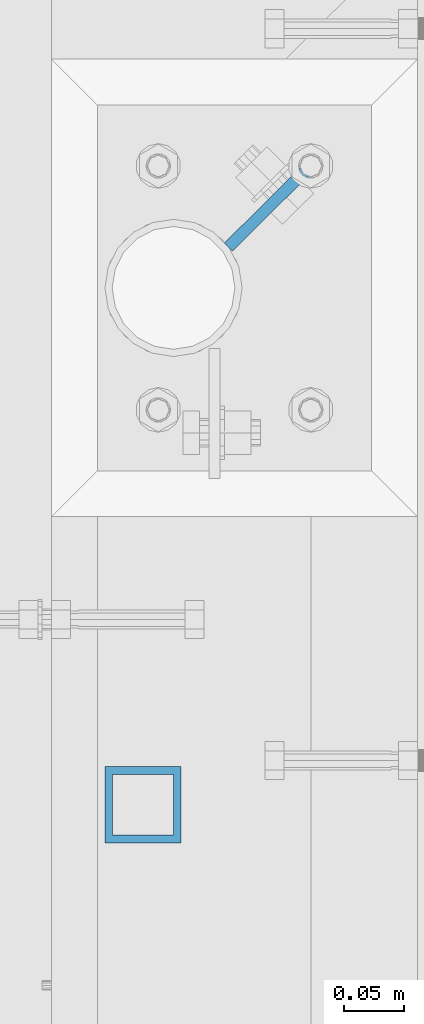
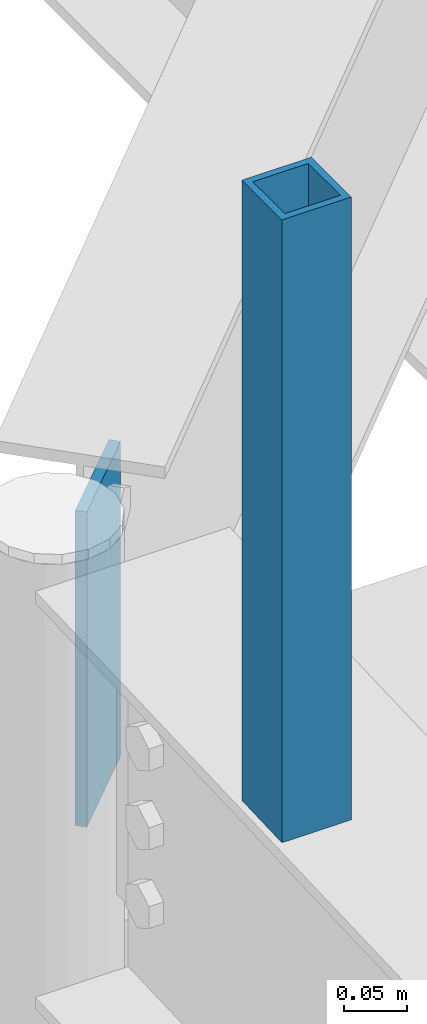
# One storey, part 208 of 975: 2 columns.
"""IFC2X3 building model written with IfcOpenShell, lengths in millimetres."""

import ifcopenshell
import ifcopenshell.guid

model = None  # the IFC model being written
_history = None  # IfcOwnerHistory: only IFC2X3 demands one
_inside = {}  # id of a spatial element -> (the spatial element, [elements in it])
_under = {}  # id of a project, library or spatial element -> (it, [spatial elements below it])
_declared = {}  # id of a project -> (the project, [libraries it declares])
_typed = {}  # id of a type object -> (the type object, [elements of that type])
_made_of = {}  # id of a material, layer set ... -> (it, [elements and type objects made of it])


def new_model(schema):
    """Start an empty IFC model of exactly this schema.

    Asked for "IFC4X3", IfcOpenShell would pick the latest addendum, in which some entities
    have other attributes; the version numbers below select the first issue.
    IFC2X3 requires an IfcOwnerHistory on every rooted entity: one is made here for all.
    """
    global model, _history
    if schema == "IFC4X3":
        model = ifcopenshell.file(schema_version=(4, 3, 0, 0))
    else:
        model = ifcopenshell.file(schema=schema)
    _inside.clear()
    _under.clear()
    _declared.clear()
    _typed.clear()
    _made_of.clear()
    _history = None
    if model.schema == "IFC2X3":
        org = make("IfcOrganization", Name="unknown")
        user = make(
            "IfcPersonAndOrganization",
            ThePerson=make("IfcPerson", FamilyName="unknown"),
            TheOrganization=org,
        )
        app = make(
            "IfcApplication",
            ApplicationDeveloper=org,
            Version="unknown",
            ApplicationFullName="unknown",
            ApplicationIdentifier="unknown",
        )
        _history = make(
            "IfcOwnerHistory",
            OwningUser=user,
            OwningApplication=app,
            ChangeAction="ADDED",
            CreationDate=0,
        )
    return model


def make(cls, **values):
    """One entity of the class cls with the attributes given. An attribute that is None is left unset."""
    return model.create_entity(
        cls, **{name: value for name, value in values.items() if value is not None}
    )


def rooted(cls, **values):
    """An entity with a GlobalId (a new one), such as an element, a storey or a relation."""
    return make(cls, GlobalId=ifcopenshell.guid.new(), OwnerHistory=_history, **values)


def si_unit(unit_type, name, prefix=None):
    """IfcSIUnit, for example si_unit("LENGTHUNIT", "METRE", prefix="MILLI")."""
    return make("IfcSIUnit", UnitType=unit_type, Prefix=prefix, Name=name)


def assignment(units):
    """IfcUnitAssignment: the units of a project."""
    return None if units is None else make("IfcUnitAssignment", Units=units)


def point(xyz):
    """IfcCartesianPoint."""
    return None if xyz is None else make("IfcCartesianPoint", Coordinates=xyz)


def direction(xyz):
    """IfcDirection."""
    return None if xyz is None else make("IfcDirection", DirectionRatios=xyz)


def frame(location, z_axis=None, x_axis=None):
    """IfcAxis2Placement3D, a coordinate frame: its origin and axes. An axis left out is left unset."""
    return make(
        "IfcAxis2Placement3D",
        Location=point(location),
        Axis=direction(z_axis),
        RefDirection=direction(x_axis),
    )


def origin_with_axes():
    """The frame at (0, 0, 0) with the z axis (0, 0, 1) and the x axis (1, 0, 0) written out."""
    return frame((0.0, 0.0, 0.0), z_axis=(0.0, 0.0, 1.0), x_axis=(1.0, 0.0, 0.0))


def place(relative_to, where):
    """IfcLocalPlacement: puts the frame where relative to a parent placement (None: the world)."""
    return make(
        "IfcLocalPlacement", PlacementRelTo=relative_to, RelativePlacement=where
    )


def context(
    kind, dimensions, precision=None, world=None, true_north=None, identifier=None
):
    """IfcGeometricRepresentationContext, for example the 3D "Model" context."""
    return make(
        "IfcGeometricRepresentationContext",
        ContextIdentifier=identifier,
        ContextType=kind,
        CoordinateSpaceDimension=dimensions,
        Precision=precision,
        WorldCoordinateSystem=world,
        TrueNorth=true_north,
    )


def subcontext(parent, identifier, kind, view, scale=None):
    """IfcGeometricRepresentationSubContext, for example "Body" below "Model"."""
    return make(
        "IfcGeometricRepresentationSubContext",
        ContextIdentifier=identifier,
        ContextType=kind,
        ParentContext=parent,
        TargetScale=scale,
        TargetView=view,
    )


def project(units=None, contexts=None):
    """IfcProject with its units and contexts."""
    return rooted(
        "IfcProject",
        Name="project",
        RepresentationContexts=contexts,
        UnitsInContext=assignment(units),
    )


def spatial(cls, under=None, at=None, **own):
    """A site, building, storey or space (cls), placed at a placement, below another one or the project."""
    s = rooted(cls, ObjectPlacement=at, **own)
    if under is not None:
        _under.setdefault(under.id(), (under, []))[1].append(s)
    return s


def faces_of(points, faces, orient=None, outer=None):
    """IfcFace entities. A face is a list of loops; a loop is a list of indices into points, from 0.

    orient and outer hold one flag for each loop. By default every Orientation is true, the
    first loop of a face is its IfcFaceOuterBound and the others are IfcFaceBound.
    """
    made = []
    for i, loops in enumerate(faces):
        bounds = []
        for j, loop in enumerate(loops):
            is_outer = j == 0 if outer is None else outer[i][j]
            bounds.append(
                make(
                    "IfcFaceOuterBound" if is_outer else "IfcFaceBound",
                    Bound=make("IfcPolyLoop", Polygon=[points[k] for k in loop]),
                    Orientation=True if orient is None else orient[i][j],
                )
            )
        made.append(make("IfcFace", Bounds=bounds))
    return made


def faceted_brep(points, faces, orient=None, outer=None, voids=None):
    """IfcFacetedBrep: a solid bounded by flat faces; with voids (closed shells), ...WithVoids."""
    shared = [point(p) for p in points]
    hull = make("IfcClosedShell", CfsFaces=faces_of(shared, faces, orient, outer))
    if voids is None:
        return make("IfcFacetedBrep", Outer=hull)
    return make(
        "IfcFacetedBrepWithVoids",
        Outer=hull,
        Voids=[
            make(cls, CfsFaces=faces_of(shared, fs, o, b)) for cls, fs, o, b in voids
        ],
    )


def shape(context_of_items, identifier, shape_type, items):
    """IfcShapeRepresentation: the items that make up one representation, for example the "Body"."""
    return make(
        "IfcShapeRepresentation",
        ContextOfItems=context_of_items,
        RepresentationIdentifier=identifier,
        RepresentationType=shape_type,
        Items=items,
    )


def material(Name=None, Category=None):
    """IfcMaterial."""
    return make("IfcMaterial", Name=Name, Category=Category)


def made_of(thing, what):
    """Note that an element or type object is made of a material, layer set ...; save() writes the relation."""
    if what is not None:
        _made_of.setdefault(what.id(), (what, []))[1].append(thing)
    return thing


def type_object(cls, material=None, **own):
    """A type object (cls), such as IfcWallType, which elements share."""
    return made_of(rooted(cls, **own), material)


def element(
    cls,
    number,
    at=None,
    inside=None,
    cuts=None,
    type_object=None,
    material=None,
    context=None,
    identifier="Body",
    shape_type=None,
    held_by="IfcProductDefinitionShape",
    body=None,
    shapes=None,
    **own,
):
    """One element of the class cls, such as IfcWall. Its Tag is "e" and its number.

    at: its placement. inside: the storey or other place that contains it. cuts: it is an
    opening in that element (IfcRelVoidsElement). A single representation is given by context,
    identifier, shape_type and body (its items); several are given by shapes. held_by: the class
    of the entity that holds the representations. save() writes the other relations.
    """
    e = rooted(cls, Tag="e%d" % number, ObjectPlacement=at, **own)
    if body is not None:
        shapes = [shape(context, identifier, shape_type, body)]
    if shapes is not None:
        e.Representation = make(held_by, Representations=shapes)
    if inside is not None:
        _inside.setdefault(inside.id(), (inside, []))[1].append(e)
    if cuts is not None:
        rooted(
            "IfcRelVoidsElement", RelatingBuildingElement=cuts, RelatedOpeningElement=e
        )
    if type_object is not None:
        _typed.setdefault(type_object.id(), (type_object, []))[1].append(e)
    return made_of(e, material)


def aggregate(whole, parts):
    """IfcRelAggregates: a whole, such as a stair, and the parts it consists of."""
    return rooted("IfcRelAggregates", RelatingObject=whole, RelatedObjects=parts)


def save(model, path):
    """Write the relations noted so far, then the file.

    IfcRelAggregates (storeys below a building ...), IfcRelContainedInSpatialStructure (elements
    in a storey), IfcRelDefinesByType, IfcRelAssociatesMaterial and IfcRelDeclares: one each for
    every whole, place, type object, material and project.
    """
    for whole, parts in _under.values():
        aggregate(whole, parts)
    for where, things in _inside.values():
        rooted(
            "IfcRelContainedInSpatialStructure",
            RelatedElements=things,
            RelatingStructure=where,
        )
    for kind, things in _typed.values():
        rooted("IfcRelDefinesByType", RelatedObjects=things, RelatingType=kind)
    for what, things in _made_of.values():
        rooted("IfcRelAssociatesMaterial", RelatedObjects=things, RelatingMaterial=what)
    for by, libraries in _declared.values():
        rooted("IfcRelDeclares", RelatingContext=by, RelatedDefinitions=libraries)
    model.write(path)


model = new_model("IFC2X3")

# Units and contexts
model_context = context("Model", 3, precision=1e-05, world=origin_with_axes())
body_context = subcontext(model_context, "Body", "Model", "MODEL_VIEW")
ifc_project = project(units=[si_unit("LENGTHUNIT", "METRE", prefix="MILLI"), si_unit("AREAUNIT", "SQUARE_METRE"), si_unit("VOLUMEUNIT", "CUBIC_METRE"), si_unit("MASSUNIT", "GRAM", prefix="KILO"), si_unit("TIMEUNIT", "SECOND"), si_unit("PLANEANGLEUNIT", "RADIAN"), si_unit("SOLIDANGLEUNIT", "STERADIAN"), si_unit("THERMODYNAMICTEMPERATUREUNIT", "DEGREE_CELSIUS"), si_unit("LUMINOUSINTENSITYUNIT", "LUMEN")], contexts=[model_context])

# Site, building, storey
site_placement = place(None, origin_with_axes())
site = spatial("IfcSite", under=ifc_project, at=site_placement, CompositionType="ELEMENT")
building_placement = place(site_placement, origin_with_axes())
building = spatial("IfcBuilding", under=site, at=building_placement, Name="Undefined", CompositionType="ELEMENT")
storey_placement = place(building_placement, origin_with_axes())
storey = spatial("IfcBuildingStorey", under=building, at=storey_placement, Name="Undefined", CompositionType="ELEMENT", Elevation=0.0)

# Columns
ifc_material_1 = material()
column_type_1 = type_object("IfcColumnType", Name="HSS2-1/2X2-1/2X1/4", PredefinedType="NOTDEFINED")
column_1_placement = place(storey_placement, frame((2092.3250634762, 14968.2361674168, 8568.33577002292), z_axis=(-0.999999999999998, 6.90000001668524e-08, 0.0), x_axis=(0.0, 0.0, 1.0)))
element("IfcColumn", 1, at=column_1_placement, inside=storey, type_object=column_type_1, material=ifc_material_1, ObjectType="HSS2-1/2X2-1/2X1/4", context=body_context, shape_type="Brep", body=[
    faceted_brep([(626.464229977082, -31.75, 31.75), (626.464229977082, 31.75, 31.75), (26.6637437582867, 31.75, 31.75), (24.136256241718, -31.75, 31.75), (626.464229977082, -31.75, -31.75), (24.136256241718, -31.75, -31.75), (626.464229977082, 31.75, -31.75), (26.6637437582867, 31.75, -31.75), (626.464229977082, -25.3999999999996, 25.4000000000001), (626.464229977082, 25.3999999999996, 25.4000000000001), (626.464229977082, 25.3999999999996, -25.4000000000001), (626.464229977082, -25.3999999999996, -25.4000000000001), (26.4109950066304, 25.3999999999996, 25.4000000000001), (26.4109950066304, 25.3999999999996, -25.4000000000001), (24.3890049933743, -25.3999999999996, -25.4000000000001), (24.3890049933743, -25.3999999999996, 25.4000000000001)], [[[0, 1, 2, 3]], [[4, 0, 3, 5]], [[6, 4, 5, 7]], [[1, 6, 7, 2]], [[0, 4, 6, 1], [8, 9, 10, 11]], [[10, 9, 12, 13]], [[11, 10, 13, 14]], [[8, 11, 14, 15]], [[9, 8, 15, 12]], [[5, 3, 2, 7], [14, 13, 12, 15]]]),
])
ifc_material_2 = material(Name="STEEL/A36")
column_type_2 = type_object("IfcColumnType", PredefinedType="NOTDEFINED")
column_2_placement = place(storey_placement, frame((2199.49439156635, 15468.5638594445, 8271.34002070163), z_axis=(-0.710504231784318, -0.703692927786386, 0.0), x_axis=(0.0, 0.0, 1.0)))
element("IfcColumn", 2, at=column_2_placement, inside=storey, type_object=column_type_2, material=ifc_material_2, Name="PLATE", context=body_context, shape_type="Brep", body=[
    faceted_brep([(6.91215973347425e-11, 4.76250000000073, -50.8000000000065), (-6.18456397205591e-11, 4.76250000000073, 50.8000000000075), (304.800000004363, 4.76250000003165, 50.7999999999793), (304.800000004363, 4.7624999999698, -50.799999999972), (-6.18456397205591e-11, -4.76250000000073, 50.8000000000075), (304.800000004363, -4.76249999996435, 50.799999999972), (6.91215973347425e-11, -4.76250000000073, -50.8000000000065), (304.800000004363, -4.76250000002619, -50.7999999999793)], [[[0, 1, 2, 3]], [[1, 4, 5, 2]], [[4, 6, 7, 5]], [[6, 0, 3, 7]], [[5, 7, 3, 2]], [[6, 4, 1, 0]]]),
])

save(model, "model.ifc")
